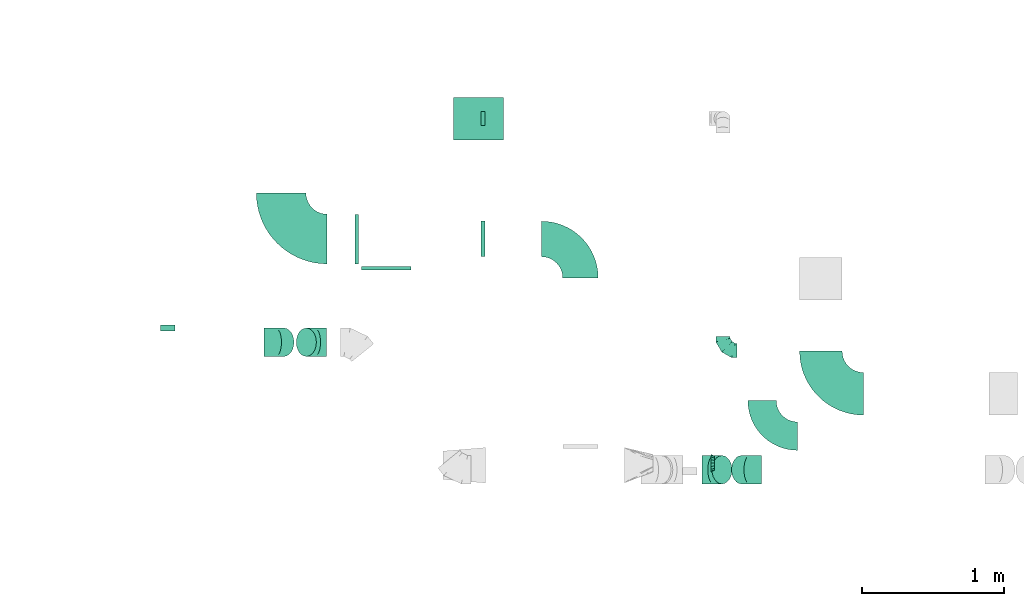
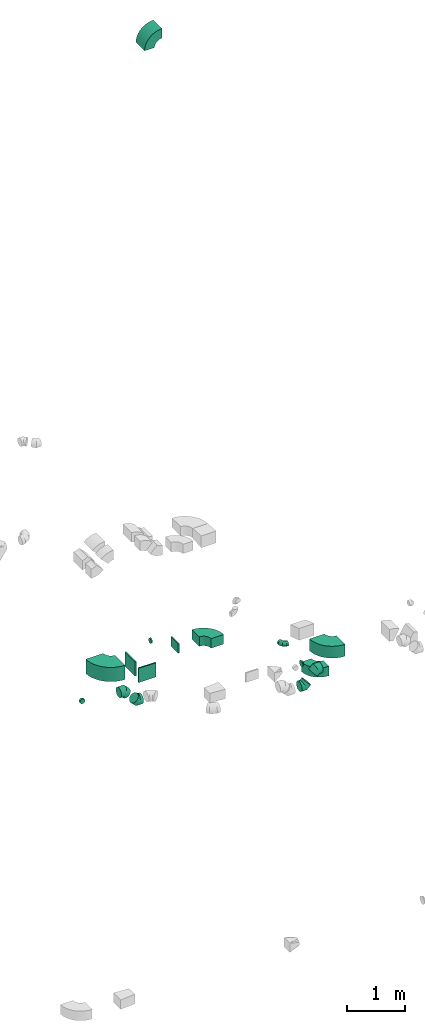
# One storey, part 29 of 44: 16 flow fittings.
"""IFC2X3 building model written with IfcOpenShell, lengths in millimetres."""

from ifc_helpers import new_model, entity, si_unit, converted_unit, derived_unit, direction, frame, frame_2d, origin, origin_2d_with_axis, place, context, subcontext, project, spatial, polyline, circle_curve, parameter, trimmed, segment, composite_curve, rectangle, outline, extrude, faceted_brep, source, transform, mapped, material, type_object, type_shapes, element, save


model = new_model("IFC2X3")

# Units and contexts
model_context = context("Model", 3, precision=0.01, world=origin(), true_north=direction((6.12303176911189e-17, 1.0)))
body_context = subcontext(model_context, "Body", "Model", "MODEL_VIEW")
ifc_project = project(units=[si_unit("LENGTHUNIT", "METRE", prefix="MILLI"), si_unit("AREAUNIT", "SQUARE_METRE"), si_unit("VOLUMEUNIT", "CUBIC_METRE"), converted_unit("PLANEANGLEUNIT", "DEGREE", entity("IfcRatioMeasure", 0.0174532925199433), si_unit("PLANEANGLEUNIT", "RADIAN"), dimensions=[0, 0, 0, 0, 0, 0, 0]), si_unit("MASSUNIT", "GRAM", prefix="KILO"), derived_unit("MASSDENSITYUNIT", [(si_unit("MASSUNIT", "GRAM", prefix="KILO"), 1), (si_unit("LENGTHUNIT", "METRE"), -3)]), derived_unit("MOMENTOFINERTIAUNIT", [(si_unit("LENGTHUNIT", "METRE"), 4)]), si_unit("TIMEUNIT", "SECOND"), si_unit("FREQUENCYUNIT", "HERTZ"), si_unit("THERMODYNAMICTEMPERATUREUNIT", "DEGREE_CELSIUS"), derived_unit("THERMALTRANSMITTANCEUNIT", [(si_unit("MASSUNIT", "GRAM", prefix="KILO"), 1), (si_unit("THERMODYNAMICTEMPERATUREUNIT", "KELVIN"), -1), (si_unit("TIMEUNIT", "SECOND"), -3)]), derived_unit("VOLUMETRICFLOWRATEUNIT", [(si_unit("LENGTHUNIT", "METRE"), 3), (si_unit("TIMEUNIT", "SECOND"), -1)]), derived_unit("MASSFLOWRATEUNIT", [(si_unit("MASSUNIT", "GRAM", prefix="KILO"), 1), (si_unit("TIMEUNIT", "SECOND"), -1)]), derived_unit("ROTATIONALFREQUENCYUNIT", [(si_unit("TIMEUNIT", "SECOND"), -1)]), si_unit("ELECTRICCURRENTUNIT", "AMPERE"), si_unit("ELECTRICVOLTAGEUNIT", "VOLT"), si_unit("POWERUNIT", "WATT"), si_unit("FORCEUNIT", "NEWTON", prefix="KILO"), si_unit("ILLUMINANCEUNIT", "LUX"), si_unit("LUMINOUSFLUXUNIT", "LUMEN"), si_unit("LUMINOUSINTENSITYUNIT", "CANDELA"), derived_unit("USERDEFINED", [(si_unit("MASSUNIT", "GRAM", prefix="KILO"), -1), (si_unit("LENGTHUNIT", "METRE"), -2), (si_unit("TIMEUNIT", "SECOND"), 3), (si_unit("LUMINOUSFLUXUNIT", "LUMEN"), 1)]), derived_unit("LINEARVELOCITYUNIT", [(si_unit("LENGTHUNIT", "METRE"), 1), (si_unit("TIMEUNIT", "SECOND"), -1)]), si_unit("PRESSUREUNIT", "PASCAL"), derived_unit("USERDEFINED", [(si_unit("LENGTHUNIT", "METRE"), -2), (si_unit("MASSUNIT", "GRAM", prefix="KILO"), 1), (si_unit("TIMEUNIT", "SECOND"), -2)]), derived_unit("LINEARFORCEUNIT", [(si_unit("MASSUNIT", "GRAM", prefix="KILO"), 1), (si_unit("LENGTHUNIT", "METRE"), 1), (si_unit("TIMEUNIT", "SECOND"), -2), (si_unit("LENGTHUNIT", "METRE"), -1)]), derived_unit("PLANARFORCEUNIT", [(si_unit("MASSUNIT", "GRAM", prefix="KILO"), 1), (si_unit("LENGTHUNIT", "METRE"), 1), (si_unit("TIMEUNIT", "SECOND"), -2), (si_unit("LENGTHUNIT", "METRE"), -2)])], contexts=[model_context])

# Site, building, storey
site_placement = place(None, origin())
site = spatial("IfcSite", under=ifc_project, at=site_placement, CompositionType="ELEMENT")
building_placement = place(site_placement, origin())
building = spatial("IfcBuilding", under=site, at=building_placement, CompositionType="ELEMENT")
storey_placement = place(building_placement, frame((0.0, 0.0, 15900.0)))
storey = spatial("IfcBuildingStorey", under=building, at=storey_placement, CompositionType="ELEMENT", Elevation=15900.0)

# Flow fittings
ifc_material = material()
duct_fitting_type_1 = type_object("IfcDuctFittingType", PredefinedType="NOTDEFINED", material=ifc_material)
shared_shape_1 = source(origin(), body_context, "Body", "SweptSolid", [
    extrude(rectangle(XDim=26.0960000000005, YDim=300.0, at=origin_2d_with_axis()), frame((6.95, 0.0, -175.0)), (0.0, 0.0, 1.0), 350.0),
])
type_shapes(duct_fitting_type_1, [shared_shape_1])
for number, where, z_axis, x_axis in (
    (1, (58980.48, 10765.63, 3158.88), (-1.0, 0.0, 0.0), (0.0, -1.0, 0.0)),
    (2, (58780.38, 10964.64, 3284.58), (0.0, 1.0, 0.0), (-1.0, 0.0, 0.0)),
):
    element("IfcFlowFitting", number, at=place(storey_placement, frame(where, z_axis=z_axis, x_axis=x_axis)), inside=storey, type_object=duct_fitting_type_1, material=ifc_material, context=body_context, shape_type="MappedRepresentation", body=[
        mapped(shared_shape_1, transform((0.0, 0.0, 0.0), scale=1.0)),
    ])
duct_fitting_type_2 = type_object("IfcDuctFittingType", PredefinedType="NOTDEFINED", material=ifc_material)
shared_shape_2 = source(origin(), body_context, "Body", "SweptSolid", [
    extrude(rectangle(XDim=26.0960000000003, YDim=200.0, at=origin_2d_with_axis()), frame((6.95, 0.0, -125.0)), (0.0, 0.0, 1.0), 250.0),
])
type_shapes(duct_fitting_type_2, [shared_shape_2])
flow_fitting_1_placement = place(storey_placement, frame((59655.56, 10965.63, 3375.0), z_axis=(0.0, -1.0, 0.0), x_axis=(1.0, 0.0, 0.0)))
element("IfcFlowFitting", 3, at=flow_fitting_1_placement, inside=storey, type_object=duct_fitting_type_2, material=ifc_material, context=body_context, shape_type="MappedRepresentation", body=[
    mapped(shared_shape_2, transform((0.0, 0.0, 0.0), scale=1.0)),
])
duct_fitting_type_3 = type_object("IfcDuctFittingType", PredefinedType="NOTDEFINED", material=ifc_material)
shared_shape_3 = source(origin(), body_context, "Body", "Brep", [
    faceted_brep([(-100.0, 0.0, -50.0), (-100.0, -12.94, -48.3), (-100.0, -25.0, -43.3), (-100.0, -35.36, -35.36), (-100.0, -43.3, -25.0), (-100.0, -48.3, -12.94), (-100.0, -50.0, 0.0), (-100.0, -48.3, 12.94), (-100.0, -43.3, 25.0), (-100.0, -35.36, 35.36), (-100.0, -25.0, 43.3), (-100.0, -12.94, 48.3), (-100.0, 0.0, 50.0), (-100.0, 12.94, 48.3), (-100.0, 25.0, 43.3), (-100.0, 35.36, 35.36), (-100.0, 43.3, 25.0), (-100.0, 48.3, 12.94), (-100.0, 50.0, 0.0), (-100.0, 48.3, -12.94), (-100.0, 43.3, -25.0), (-100.0, 35.36, -35.36), (-100.0, 25.0, -43.3), (-100.0, 12.94, -48.3), (-76.67, 12.94, 48.3), (-79.9, 25.0, 43.3), (-73.21, 0.0, 50.0), (-82.68, 35.36, 35.36), (-86.15, 48.3, 12.94), (-86.6, 50.0, 0.0), (-84.81, 43.3, 25.0), (-84.81, 43.3, -25.0), (-82.68, 35.36, -35.36), (-86.15, 48.3, -12.94), (-76.67, 12.94, -48.3), (-73.21, 0.0, -50.0), (-79.9, 25.0, -43.3), (-69.74, -12.94, -48.3), (-66.51, -25.0, -43.3), (-63.73, -35.36, -35.36), (-61.6, -43.3, -25.0), (-60.26, -48.3, -12.94), (-59.81, -50.0, 0.0), (-60.26, -48.3, 12.94), (-61.6, -43.3, 25.0), (-63.73, -35.36, 35.36), (-66.51, -25.0, 43.3), (-69.74, -12.94, 48.3), (-36.27, 36.27, 48.3), (-45.1, 45.1, 43.3), (-26.79, 26.79, 50.0), (-52.68, 52.68, 35.36), (-58.49, 58.49, 25.0), (-62.15, 62.15, 12.94), (-63.4, 63.4, 0.0), (-62.15, 62.15, -12.94), (-58.49, 58.49, -25.0), (-52.68, 52.68, -35.36), (-36.27, 36.27, -48.3), (-26.79, 26.79, -50.0), (-45.1, 45.1, -43.3), (-17.32, 17.32, -48.3), (-8.49, 8.49, -43.3), (-0.91, 0.91, -35.36), (4.9, -4.9, -25.0), (8.56, -8.56, -12.94), (9.81, -9.81, 0.0), (8.56, -8.56, 12.94), (4.9, -4.9, 25.0), (-0.91, 0.91, 35.36), (-8.49, 8.49, 43.3), (-17.32, 17.32, 48.3), (-12.94, 76.67, 48.3), (-25.0, 79.9, 43.3), (0.0, 73.21, 50.0), (-35.36, 82.68, 35.36), (-43.3, 84.81, 25.0), (-48.3, 86.15, 12.94), (-50.0, 86.6, 0.0), (-48.3, 86.15, -12.94), (-43.3, 84.81, -25.0), (-35.36, 82.68, -35.36), (-12.94, 76.67, -48.3), (0.0, 73.21, -50.0), (-25.0, 79.9, -43.3), (12.94, 69.74, -48.3), (25.0, 66.51, -43.3), (35.36, 63.73, -35.36), (43.3, 61.6, -25.0), (48.3, 60.26, -12.94), (50.0, 59.81, 0.0), (48.3, 60.26, 12.94), (43.3, 61.6, 25.0), (35.36, 63.73, 35.36), (25.0, 66.51, 43.3), (12.94, 69.74, 48.3), (-12.94, 100.0, -48.3), (-25.0, 100.0, -43.3), (-35.36, 100.0, -35.36), (-43.3, 100.0, -25.0), (-48.3, 100.0, -12.94), (-50.0, 100.0, 0.0), (-48.3, 100.0, 12.94), (-43.3, 100.0, 25.0), (-35.36, 100.0, 35.36), (-25.0, 100.0, 43.3), (-12.94, 100.0, 48.3), (0.0, 100.0, 50.0), (12.94, 100.0, 48.3), (25.0, 100.0, 43.3), (35.36, 100.0, 35.36), (43.3, 100.0, 25.0), (48.3, 100.0, 12.94), (50.0, 100.0, 0.0), (48.3, 100.0, -12.94), (43.3, 100.0, -25.0), (35.36, 100.0, -35.36), (25.0, 100.0, -43.3), (12.94, 100.0, -48.3), (0.0, 100.0, -50.0)], [[[0, 1, 2, 3, 4, 5, 6, 7, 8, 9, 10, 11, 12, 13, 14, 15, 16, 17, 18, 19, 20, 21, 22, 23]], [[24, 25, 14, 13]], [[26, 24, 13, 12]], [[14, 25, 27, 15]], [[28, 29, 18, 17]], [[30, 28, 17, 16]], [[15, 27, 30, 16]], [[20, 31, 32, 21]], [[33, 31, 20, 19]], [[18, 29, 33, 19]], [[34, 35, 0, 23]], [[36, 34, 23, 22]], [[32, 36, 22, 21]], [[2, 1, 37, 38]], [[3, 2, 38, 39]], [[0, 35, 37, 1]], [[5, 4, 40, 41]], [[6, 5, 41, 42]], [[3, 39, 40, 4]], [[6, 42, 43, 7]], [[7, 43, 44, 8]], [[8, 44, 45, 9]], [[10, 46, 47, 11]], [[11, 47, 26, 12]], [[10, 9, 45, 46]], [[48, 49, 25, 24]], [[50, 48, 24, 26]], [[27, 25, 49, 51]], [[52, 53, 28, 30]], [[51, 52, 30, 27]], [[29, 28, 53, 54]], [[55, 56, 31, 33]], [[54, 55, 33, 29]], [[57, 32, 31, 56]], [[58, 59, 35, 34]], [[60, 58, 34, 36]], [[57, 60, 36, 32]], [[37, 35, 59, 61]], [[38, 37, 61, 62]], [[39, 38, 62, 63]], [[41, 40, 64, 65]], [[42, 41, 65, 66]], [[63, 64, 40, 39]], [[43, 42, 66, 67]], [[44, 43, 67, 68]], [[68, 69, 45, 44]], [[46, 45, 69, 70]], [[47, 46, 70, 71]], [[26, 47, 71, 50]], [[72, 73, 49, 48]], [[74, 72, 48, 50]], [[51, 49, 73, 75]], [[76, 77, 53, 52]], [[75, 76, 52, 51]], [[54, 53, 77, 78]], [[79, 80, 56, 55]], [[78, 79, 55, 54]], [[81, 57, 56, 80]], [[82, 83, 59, 58]], [[84, 82, 58, 60]], [[81, 84, 60, 57]], [[61, 59, 83, 85]], [[62, 61, 85, 86]], [[63, 62, 86, 87]], [[65, 64, 88, 89]], [[66, 65, 89, 90]], [[87, 88, 64, 63]], [[67, 66, 90, 91]], [[68, 67, 91, 92]], [[92, 93, 69, 68]], [[70, 69, 93, 94]], [[71, 70, 94, 95]], [[50, 71, 95, 74]], [[96, 97, 98, 99, 100, 101, 102, 103, 104, 105, 106, 107, 108, 109, 110, 111, 112, 113, 114, 115, 116, 117, 118, 119]], [[72, 74, 107, 106]], [[73, 72, 106, 105]], [[75, 73, 105, 104]], [[77, 76, 103, 102]], [[78, 77, 102, 101]], [[75, 104, 103, 76]], [[78, 101, 100, 79]], [[79, 100, 99, 80]], [[80, 99, 98, 81]], [[96, 119, 83, 82]], [[97, 96, 82, 84]], [[84, 81, 98, 97]], [[83, 119, 118, 85]], [[85, 118, 117, 86]], [[86, 117, 116, 87]], [[88, 115, 114, 89]], [[89, 114, 113, 90]], [[87, 116, 115, 88]], [[91, 90, 113, 112]], [[92, 91, 112, 111]], [[93, 92, 111, 110]], [[95, 94, 109, 108]], [[74, 95, 108, 107]], [[110, 109, 94, 93]]]),
])
type_shapes(duct_fitting_type_3, [shared_shape_3])
flow_fitting_2_placement = place(storey_placement, frame((61355.06, 10179.05, 3260.0), z_axis=(0.0, 0.0, 1.0), x_axis=(0.0, -1.0, 0.0)))
element("IfcFlowFitting", 4, at=flow_fitting_2_placement, inside=storey, type_object=duct_fitting_type_3, material=ifc_material, context=body_context, shape_type="MappedRepresentation", body=[
    mapped(shared_shape_3, transform((0.0, 0.0, 0.0), scale=1.0)),
])
duct_fitting_type_4 = type_object("IfcDuctFittingType", PredefinedType="NOTDEFINED", material=ifc_material)
shared_shape_4 = source(origin(), body_context, "Body", "Brep", [
    faceted_brep([(-82.84, 0.0, -100.0), (-82.84, -25.88, -96.59), (-82.84, -50.0, -86.6), (-82.84, -70.71, -70.71), (-82.84, -86.6, -50.0), (-82.84, -96.59, -25.88), (-82.84, -100.0, 0.0), (-82.84, -96.59, 25.88), (-82.84, -86.6, 50.0), (-82.84, -70.71, 70.71), (-82.84, -50.0, 86.6), (-82.84, -25.88, 96.59), (-82.84, 0.0, 100.0), (-82.84, 25.88, 96.59), (-82.84, 50.0, 86.6), (-82.84, 70.71, 70.71), (-82.84, 86.6, 50.0), (-82.84, 96.59, 25.88), (-82.84, 100.0, 0.0), (-82.84, 96.59, -25.88), (-82.84, 86.6, -50.0), (-82.84, 70.71, -70.71), (-82.84, 50.0, -86.6), (-82.84, 25.88, -96.59), (-10.72, 25.88, 96.59), (-20.71, 50.0, 86.6), (0.0, 0.0, 100.0), (-29.29, 70.71, 70.71), (-35.87, 86.6, 50.0), (-40.01, 96.59, 25.88), (-41.42, 100.0, 0.0), (-40.01, 96.59, -25.88), (-35.87, 86.6, -50.0), (-29.29, 70.71, -70.71), (-10.72, 25.88, -96.59), (0.0, 0.0, -100.0), (-20.71, 50.0, -86.6), (10.72, -25.88, -96.59), (20.71, -50.0, -86.6), (29.29, -70.71, -70.71), (35.87, -86.6, -50.0), (40.01, -96.59, -25.88), (41.42, -100.0, 0.0), (40.01, -96.59, 25.88), (35.87, -86.6, 50.0), (29.29, -70.71, 70.71), (20.71, -50.0, 86.6), (10.72, -25.88, 96.59), (58.58, 58.58, 100.0), (40.28, 76.88, 96.59), (23.22, 93.93, 86.6), (8.58, 108.58, 70.71), (-2.66, 119.82, 50.0), (-9.72, 126.88, 25.88), (-12.13, 129.29, 0.0), (-9.72, 126.88, -25.88), (-2.66, 119.82, -50.0), (8.58, 108.58, -70.71), (23.22, 93.93, -86.6), (40.28, 76.88, -96.59), (58.58, 58.58, -100.0), (76.88, 40.28, -96.59), (93.93, 23.22, -86.6), (108.58, 8.58, -70.71), (119.82, -2.66, -50.0), (126.88, -9.72, -25.88), (129.29, -12.13, 0.0), (126.88, -9.72, 25.88), (119.82, -2.66, 50.0), (108.58, 8.58, 70.71), (93.93, 23.22, 86.6), (76.88, 40.28, 96.59)], [[[0, 1, 2, 3, 4, 5, 6, 7, 8, 9, 10, 11, 12, 13, 14, 15, 16, 17, 18, 19, 20, 21, 22, 23]], [[24, 25, 14, 13]], [[26, 24, 13, 12]], [[14, 25, 27, 15]], [[28, 29, 17, 16]], [[28, 16, 15, 27]], [[30, 18, 17, 29]], [[31, 32, 20, 19]], [[30, 31, 19, 18]], [[32, 33, 21, 20]], [[34, 35, 0, 23]], [[36, 34, 23, 22]], [[33, 36, 22, 21]], [[1, 0, 35, 37]], [[2, 1, 37, 38]], [[38, 39, 3, 2]], [[5, 4, 40, 41]], [[6, 5, 41, 42]], [[39, 40, 4, 3]], [[6, 42, 43, 7]], [[7, 43, 44, 8]], [[8, 44, 45, 9]], [[9, 45, 46, 10]], [[10, 46, 47, 11]], [[26, 12, 11, 47]], [[24, 26, 48, 49]], [[25, 24, 49, 50]], [[27, 25, 50, 51]], [[29, 28, 52, 53]], [[30, 29, 53, 54]], [[51, 52, 28, 27]], [[30, 54, 55, 31]], [[31, 55, 56, 32]], [[57, 33, 32, 56]], [[36, 58, 59, 34]], [[34, 59, 60, 35]], [[58, 36, 33, 57]], [[35, 60, 61, 37]], [[37, 61, 62, 38]], [[63, 39, 38, 62]], [[40, 64, 65, 41]], [[41, 65, 66, 42]], [[64, 40, 39, 63]], [[43, 42, 66, 67]], [[44, 43, 67, 68]], [[68, 69, 45, 44]], [[47, 46, 70, 71]], [[26, 47, 71, 48]], [[69, 70, 46, 45]], [[59, 58, 57, 56, 55, 54, 53, 52, 51, 50, 49, 48, 71, 70, 69, 68, 67, 66, 65, 64, 63, 62, 61, 60]]]),
])
type_shapes(duct_fitting_type_4, [shared_shape_4])
for number, where, z_axis, x_axis in (
    (5, (58475.71, 10237.4, 3074.82), (0.0, 1.0, 0.0), (-1.0, 0.0, 0.0)),
    (6, (58200.53, 10237.4, 3350.0), (0.0, -1.0, 0.0), (-0.70710678118653, 0.0, 0.707106781186565)),
    (7, (61288.67, 9338.57, 2945.0), (0.0, -1.0, 0.0), (1.0, 0.0, 0.0)),
    (8, (61543.67, 9338.57, 3200.0), (0.0, 1.0, 0.0), (0.707106781186468, 0.0, 0.707106781186627)),
):
    element("IfcFlowFitting", number, at=place(storey_placement, frame(where, z_axis=z_axis, x_axis=x_axis)), inside=storey, type_object=duct_fitting_type_4, material=ifc_material, context=body_context, shape_type="MappedRepresentation", body=[
        mapped(shared_shape_4, transform((0.0, 0.0, 0.0), scale=1.0)),
    ])
duct_fitting_type_5 = type_object("IfcDuctFittingType", PredefinedType="NOTDEFINED", material=ifc_material)
shared_shape_5 = source(origin(), body_context, "Body", "Brep", [
    faceted_brep([(20.0, 0.0, -50.0), (20.0, 12.94, -48.3), (20.0, 25.0, -43.3), (20.0, 35.36, -35.36), (20.0, 43.3, -25.0), (20.0, 48.3, -12.94), (20.0, 50.0, 0.0), (20.0, 48.3, 12.94), (20.0, 43.3, 25.0), (20.0, 35.36, 35.36), (20.0, 25.0, 43.3), (20.0, 12.94, 48.3), (20.0, 0.0, 50.0), (20.0, -12.94, 48.3), (20.0, -25.0, 43.3), (20.0, -35.36, 35.36), (20.0, -43.3, 25.0), (20.0, -48.3, 12.94), (20.0, -50.0, 0.0), (20.0, -48.3, -12.94), (20.0, -43.3, -25.0), (20.0, -35.36, -35.36), (20.0, -25.0, -43.3), (20.0, -12.94, -48.3), (0.0, 0.0, 50.0), (-19.49, 0.0, 50.0), (-19.49, -12.94, 48.3), (0.0, -12.94, 48.3), (-19.49, -25.0, 43.3), (0.0, -25.0, 43.3), (0.0, -35.36, 35.36), (-19.49, -35.36, 35.36), (0.0, -43.3, 25.0), (-19.49, -43.3, 25.0), (-19.49, -48.3, 12.94), (0.0, -48.3, 12.94), (-19.49, -50.0, 0.0), (0.0, -50.0, 0.0), (-19.49, -48.3, -12.94), (0.0, -48.3, -12.94), (-19.49, -43.3, -25.0), (0.0, -43.3, -25.0), (0.0, -35.36, -35.36), (-19.49, -35.36, -35.36), (0.0, -25.0, -43.3), (-19.49, -25.0, -43.3), (-19.49, -12.94, -48.3), (0.0, -12.94, -48.3), (-19.49, 0.0, -50.0), (0.0, 0.0, -50.0), (-19.49, 12.94, -48.3), (0.0, 12.94, -48.3), (-19.49, 25.0, -43.3), (0.0, 25.0, -43.3), (0.0, 35.36, -35.36), (-19.49, 35.36, -35.36), (0.0, 43.3, -25.0), (-19.49, 43.3, -25.0), (-19.49, 48.3, -12.94), (0.0, 48.3, -12.94), (-19.49, 50.0, 0.0), (0.0, 50.0, 0.0), (-19.49, 48.3, 12.94), (0.0, 48.3, 12.94), (-19.49, 43.3, 25.0), (0.0, 43.3, 25.0), (0.0, 35.36, 35.36), (-19.49, 35.36, 35.36), (0.0, 25.0, 43.3), (-19.49, 25.0, 43.3), (-19.49, 12.94, 48.3), (0.0, 12.94, 48.3)], [[[0, 1, 2, 3, 4, 5, 6, 7, 8, 9, 10, 11, 12, 13, 14, 15, 16, 17, 18, 19, 20, 21, 22, 23]], [[13, 12, 24, 25, 26, 27]], [[14, 13, 27, 26, 28, 29]], [[30, 15, 14, 29, 28, 31]], [[17, 16, 32, 33, 34, 35]], [[18, 17, 35, 34, 36, 37]], [[32, 16, 15, 30, 31, 33]], [[19, 18, 37, 36, 38, 39]], [[20, 19, 39, 38, 40, 41]], [[42, 21, 20, 41, 40, 43]], [[23, 22, 44, 45, 46, 47]], [[0, 23, 47, 46, 48, 49]], [[44, 22, 21, 42, 43, 45]], [[1, 0, 49, 48, 50, 51]], [[2, 1, 51, 50, 52, 53]], [[54, 3, 2, 53, 52, 55]], [[5, 4, 56, 57, 58, 59]], [[6, 5, 59, 58, 60, 61]], [[56, 4, 3, 54, 55, 57]], [[7, 6, 61, 60, 62, 63]], [[8, 7, 63, 62, 64, 65]], [[66, 9, 8, 65, 64, 67]], [[11, 10, 68, 69, 70, 71]], [[12, 11, 71, 70, 25, 24]], [[68, 10, 9, 66, 67, 69]], [[46, 45, 43, 40, 38, 36, 34, 33, 31, 28, 26, 25, 70, 69, 67, 64, 62, 60, 58, 57, 55, 52, 50, 48]]]),
])
type_shapes(duct_fitting_type_5, [shared_shape_5])
flow_fitting_3_placement = place(storey_placement, frame((57439.44, 10337.4, 3350.0), z_axis=(0.0, 7.45053264831263e-07, -1.0), x_axis=(0.0, 1.0, 7.45053263408281e-07)))
element("IfcFlowFitting", 9, at=flow_fitting_3_placement, inside=storey, type_object=duct_fitting_type_5, material=ifc_material, context=body_context, shape_type="MappedRepresentation", body=[
    mapped(shared_shape_5, transform((0.0, 0.0, 0.0), scale=1.0)),
])
duct_fitting_type_6 = type_object("IfcDuctFittingType", PredefinedType="NOTDEFINED", material=ifc_material)
shared_shape_6 = source(origin(), body_context, "Body", "Brep", [
    faceted_brep([(25.0, 0.0, -62.5), (25.0, 12.45, -60.02), (25.0, 23.92, -57.74), (25.0, 34.06, -50.97), (25.0, 44.19, -44.19), (25.0, 50.97, -34.06), (25.0, 57.74, -23.92), (25.0, 60.02, -12.45), (25.0, 62.5, 0.0), (25.0, 60.02, 12.45), (25.0, 57.74, 23.92), (25.0, 50.97, 34.06), (25.0, 44.19, 44.19), (25.0, 34.06, 50.97), (25.0, 23.92, 57.74), (25.0, 12.45, 60.02), (25.0, 0.0, 62.5), (25.0, -12.45, 60.02), (25.0, -23.92, 57.74), (25.0, -34.06, 50.97), (25.0, -44.19, 44.19), (25.0, -50.97, 34.06), (25.0, -57.74, 23.92), (25.0, -60.02, 12.45), (25.0, -62.5, 0.0), (25.0, -60.02, -12.45), (25.0, -57.74, -23.92), (25.0, -50.97, -34.06), (25.0, -44.19, -44.19), (25.0, -34.06, -50.97), (25.0, -23.92, -57.74), (25.0, -12.45, -60.02), (0.0, -19.13, -46.19), (0.0, -27.24, -40.77), (0.0, -35.36, -35.36), (0.0, -40.77, -27.24), (0.0, -46.19, -19.13), (0.0, -48.1, -9.57), (0.0, -50.0, 0.0), (0.0, -48.1, 9.57), (0.0, -46.19, 19.13), (0.0, -40.77, 27.24), (0.0, -35.36, 35.36), (0.0, -27.24, 40.77), (0.0, -19.13, 46.19), (0.0, -9.57, 48.1), (0.0, 0.0, 50.0), (0.0, 9.57, 48.1), (0.0, 19.13, 46.19), (0.0, 27.24, 40.77), (0.0, 35.36, 35.36), (0.0, 40.77, 27.24), (0.0, 46.19, 19.13), (0.0, 48.1, 9.57), (0.0, 50.0, 0.0), (0.0, 48.1, -9.57), (0.0, 46.19, -19.13), (0.0, 40.77, -27.24), (0.0, 35.36, -35.36), (0.0, 27.24, -40.77), (0.0, 19.13, -46.19), (0.0, 9.57, -48.1), (0.0, 0.0, -50.0), (0.0, -9.57, -48.1)], [[[0, 1, 2, 3, 4, 5, 6, 7, 8, 9, 10, 11, 12, 13, 14, 15, 16, 17, 18, 19, 20, 21, 22, 23, 24, 25, 26, 27, 28, 29, 30, 31]], [[32, 33, 34, 35, 36, 37, 38, 39, 40, 41, 42, 43, 44, 45, 46, 47, 48, 49, 50, 51, 52, 53, 54, 55, 56, 57, 58, 59, 60, 61, 62, 63]], [[52, 10, 9, 8, 54, 53]], [[51, 50, 12, 11, 10, 52]], [[47, 46, 16, 15, 14, 48]], [[49, 48, 14, 13, 12, 50]], [[44, 18, 17, 16, 46, 45]], [[43, 42, 20, 19, 18, 44]], [[39, 38, 24, 23, 22, 40]], [[41, 40, 22, 21, 20, 42]], [[36, 26, 25, 24, 38, 37]], [[35, 34, 28, 27, 26, 36]], [[63, 62, 0, 31, 30, 32]], [[33, 32, 30, 29, 28, 34]], [[60, 2, 1, 0, 62, 61]], [[59, 58, 4, 3, 2, 60]], [[55, 54, 8, 7, 6, 56]], [[57, 56, 6, 5, 4, 58]]]),
])
type_shapes(duct_fitting_type_6, [shared_shape_6])
flow_fitting_4_placement = place(storey_placement, frame((61294.84, 9385.12, 3375.0), z_axis=(0.0, 0.0, 1.0), x_axis=(-1.0, 0.0, 0.0)))
element("IfcFlowFitting", 10, at=flow_fitting_4_placement, inside=storey, type_object=duct_fitting_type_6, material=ifc_material, context=body_context, shape_type="MappedRepresentation", body=[
    mapped(shared_shape_6, transform((0.0, 0.0, 0.0), scale=1.0)),
])
duct_fitting_type_7 = type_object("IfcDuctFittingType", PredefinedType="NOTDEFINED", material=ifc_material)
shared_shape_7 = source(origin(), body_context, "Body", "Brep", [
    faceted_brep([(20.0, 12.94, -48.3), (20.0, 25.0, -43.3), (20.0, 35.36, -35.36), (20.0, 43.3, -25.0), (20.0, 48.3, -12.94), (20.0, 50.0, 0.0), (20.0, 48.3, 12.94), (20.0, 43.3, 25.0), (20.0, 35.36, 35.36), (20.0, 25.0, 43.3), (20.0, 12.94, 48.3), (20.0, 0.0, 50.0), (20.0, -12.94, 48.3), (20.0, -25.0, 43.3), (20.0, -35.36, 35.36), (20.0, -43.3, 25.0), (20.0, -48.3, 12.94), (20.0, -50.0, 0.0), (20.0, -48.3, -12.94), (20.0, -43.3, -25.0), (20.0, -35.36, -35.36), (20.0, -25.0, -43.3), (20.0, -12.94, -48.3), (20.0, 0.0, -50.0), (0.0, 0.0, 50.0), (0.0, 12.94, 48.3), (-6.1, 12.94, 48.3), (-6.1, 0.0, 50.0), (0.0, 25.0, 43.3), (-6.1, 25.0, 43.3), (0.0, 35.36, 35.36), (-6.1, 35.36, 35.36), (0.0, 43.3, 25.0), (0.0, 48.3, 12.94), (-6.1, 48.3, 12.94), (-6.1, 43.3, 25.0), (0.0, 50.0, 0.0), (-6.1, 50.0, 0.0), (0.0, 48.3, -12.94), (-6.1, 48.3, -12.94), (0.0, 43.3, -25.0), (-6.1, 43.3, -25.0), (0.0, 35.36, -35.36), (-6.1, 35.36, -35.36), (0.0, 25.0, -43.3), (0.0, 12.94, -48.3), (-6.1, 12.94, -48.3), (-6.1, 25.0, -43.3), (0.0, 0.0, -50.0), (-6.1, 0.0, -50.0), (0.0, -12.94, -48.3), (-6.1, -12.94, -48.3), (0.0, -25.0, -43.3), (-6.1, -25.0, -43.3), (0.0, -35.36, -35.36), (-6.1, -35.36, -35.36), (0.0, -43.3, -25.0), (0.0, -48.3, -12.94), (-6.1, -48.3, -12.94), (-6.1, -43.3, -25.0), (0.0, -50.0, 0.0), (-6.1, -50.0, 0.0), (0.0, -48.3, 12.94), (-6.1, -48.3, 12.94), (0.0, -43.3, 25.0), (-6.1, -43.3, 25.0), (0.0, -35.36, 35.36), (-6.1, -35.36, 35.36), (0.0, -25.0, 43.3), (0.0, -12.94, 48.3), (-6.1, -12.94, 48.3), (-6.1, -25.0, 43.3)], [[[0, 1, 2, 3, 4, 5, 6, 7, 8, 9, 10, 11, 12, 13, 14, 15, 16, 17, 18, 19, 20, 21, 22, 23]], [[24, 11, 10, 25, 26, 27]], [[25, 10, 9, 28, 29, 26]], [[28, 9, 8, 30, 31, 29]], [[32, 7, 6, 33, 34, 35]], [[33, 6, 5, 36, 37, 34]], [[30, 8, 7, 32, 35, 31]], [[36, 5, 4, 38, 39, 37]], [[38, 4, 3, 40, 41, 39]], [[40, 3, 2, 42, 43, 41]], [[44, 1, 0, 45, 46, 47]], [[45, 0, 23, 48, 49, 46]], [[42, 2, 1, 44, 47, 43]], [[48, 23, 22, 50, 51, 49]], [[50, 22, 21, 52, 53, 51]], [[52, 21, 20, 54, 55, 53]], [[56, 19, 18, 57, 58, 59]], [[57, 18, 17, 60, 61, 58]], [[54, 20, 19, 56, 59, 55]], [[60, 17, 16, 62, 63, 61]], [[62, 16, 15, 64, 65, 63]], [[64, 15, 14, 66, 67, 65]], [[68, 13, 12, 69, 70, 71]], [[69, 12, 11, 24, 27, 70]], [[66, 14, 13, 68, 71, 67]], [[49, 51, 53, 55, 59, 58, 61, 63, 65, 67, 71, 70, 27, 26, 29, 31, 35, 34, 37, 39, 41, 43, 47, 46]]]),
])
type_shapes(duct_fitting_type_7, [shared_shape_7])
flow_fitting_5_placement = place(storey_placement, frame((59655.69, 11814.05, 2950.0), z_axis=(0.0, -1.0, 0.0), x_axis=(1.0, 0.0, 0.0)))
element("IfcFlowFitting", 11, at=flow_fitting_5_placement, inside=storey, type_object=duct_fitting_type_7, material=ifc_material, context=body_context, shape_type="MappedRepresentation", body=[
    mapped(shared_shape_7, transform((0.0, 0.0, 0.0), scale=1.0)),
])
duct_fitting_type_8 = type_object("IfcDuctFittingType", PredefinedType="NOTDEFINED", material=ifc_material)
shared_shape_8 = source(origin(), body_context, "Body", "SweptSolid", [
    extrude(outline(composite_curve([segment(polyline([(-300.0, -150.0), (0.0, -150.0)]), True, "CONTINUOUS"), segment(trimmed(circle_curve(frame_2d((150.0, -150.0), x_axis=(0.0, 1.0)), 150.0), [parameter(0.0)], [parameter(90.0)], True, "PARAMETER"), False, "CONTINUOUS"), segment(polyline([(150.0, 0.0), (150.0, 300.0)]), True, "CONTINUOUS"), segment(trimmed(circle_curve(frame_2d((150.0, -150.0), x_axis=(0.0, 1.0)), 450.0), [parameter(0.0)], [parameter(90.0000000000001)], True, "PARAMETER"), True, "CONTINUOUS")], self_intersect=False)), frame((-150.0, 150.0, -125.0), z_axis=(0.0, 0.0, 1.0), x_axis=(-1.0, 0.0, 0.0)), (0.0, 0.0, 1.0), 250.0),
])
type_shapes(duct_fitting_type_8, [shared_shape_8])
flow_fitting_6_placement = place(storey_placement, frame((62044.65, 9874.07, 3075.0), z_axis=(0.0, 0.0, 1.0), x_axis=(0.0, -1.0, 0.0)))
element("IfcFlowFitting", 12, at=flow_fitting_6_placement, inside=storey, type_object=duct_fitting_type_8, material=ifc_material, context=body_context, shape_type="MappedRepresentation", body=[
    mapped(shared_shape_8, transform((0.0, 0.0, 0.0), scale=1.0)),
])
duct_fitting_type_9 = type_object("IfcDuctFittingType", PredefinedType="NOTDEFINED", material=ifc_material)
shared_shape_9 = source(origin(), body_context, "Body", "SweptSolid", [
    extrude(outline(composite_curve([segment(polyline([(-262.5, -137.5), (-12.5, -137.5)]), True, "CONTINUOUS"), segment(trimmed(circle_curve(frame_2d((137.5, -137.5), x_axis=(0.0, 1.0)), 150.0), [parameter(0.0)], [parameter(90.0000000000001)], True, "PARAMETER"), False, "CONTINUOUS"), segment(polyline([(137.5, 12.5), (137.5, 262.5)]), True, "CONTINUOUS"), segment(trimmed(circle_curve(frame_2d((137.5, -137.5), x_axis=(0.0, 1.0)), 400.0), [parameter(0.0)], [parameter(90.0000000000001)], True, "PARAMETER"), True, "CONTINUOUS")], self_intersect=False)), frame((-137.5, 137.5, -100.0), z_axis=(0.0, 0.0, 1.0), x_axis=(-1.0, 0.0, 0.0)), (0.0, 0.0, 1.0), 200.0),
])
type_shapes(duct_fitting_type_9, [shared_shape_9])
flow_fitting_7_placement = place(storey_placement, frame((60349.84, 10965.63, 3375.0), z_axis=(0.0, 0.0, 1.0), x_axis=(0.0, 1.0, 0.0)))
element("IfcFlowFitting", 13, at=flow_fitting_7_placement, inside=storey, type_object=duct_fitting_type_9, material=ifc_material, context=body_context, shape_type="MappedRepresentation", body=[
    mapped(shared_shape_9, transform((0.0, 0.0, 0.0), scale=1.0)),
])
duct_fitting_type_10 = type_object("IfcDuctFittingType", PredefinedType="NOTDEFINED", material=ifc_material)
shared_shape_10 = source(origin(), body_context, "Body", "SweptSolid", [
    extrude(outline(composite_curve([segment(polyline([(-337.5, -162.5), (12.5, -162.5)]), True, "CONTINUOUS"), segment(trimmed(circle_curve(frame_2d((162.5, -162.5), x_axis=(0.0, 1.0)), 150.0), [parameter(0.0)], [parameter(90.0)], True, "PARAMETER"), False, "CONTINUOUS"), segment(polyline([(162.5, -12.5), (162.5, 337.5)]), True, "CONTINUOUS"), segment(trimmed(circle_curve(frame_2d((162.5, -162.5), x_axis=(0.0, 1.0)), 500.0), [parameter(0.0)], [parameter(90.0)], True, "PARAMETER"), True, "CONTINUOUS")], self_intersect=False)), frame((-162.5, 162.5, -150.0), z_axis=(0.0, 0.0, 1.0), x_axis=(-1.0, 0.0, 0.0)), (0.0, 0.0, 1.0), 300.0),
])
type_shapes(duct_fitting_type_10, [shared_shape_10])
flow_fitting_8_placement = place(storey_placement, frame((58239.44, 10964.64, 3284.58), z_axis=(0.0, 0.0, 1.0), x_axis=(0.0, -1.0, 0.0)))
element("IfcFlowFitting", 14, at=flow_fitting_8_placement, inside=storey, type_object=duct_fitting_type_10, material=ifc_material, context=body_context, shape_type="MappedRepresentation", body=[
    mapped(shared_shape_10, transform((0.0, 0.0, 0.0), scale=1.0)),
])
duct_fitting_type_11 = type_object("IfcDuctFittingType", PredefinedType="NOTDEFINED", material=ifc_material)
shared_shape_11 = source(origin(), body_context, "Body", "SweptSolid", [
    extrude(outline(composite_curve([segment(polyline([(-225.0, -125.0), (-25.0, -125.0)]), True, "CONTINUOUS"), segment(trimmed(circle_curve(frame_2d((125.0, -125.0), x_axis=(0.0, 1.0)), 150.0), [parameter(0.0)], [parameter(90.0)], True, "PARAMETER"), False, "CONTINUOUS"), segment(polyline([(125.0, 25.0), (125.0, 225.0)]), True, "CONTINUOUS"), segment(trimmed(circle_curve(frame_2d((125.0, -125.0), x_axis=(0.0, 1.0)), 350.0), [parameter(0.0)], [parameter(90.0)], True, "PARAMETER"), True, "CONTINUOUS")], self_intersect=False)), frame((-125.0, 125.0, -100.0), z_axis=(0.0, 0.0, 1.0), x_axis=(-1.0, 0.0, 0.0)), (0.0, 0.0, 1.0), 200.0),
])
type_shapes(duct_fitting_type_11, [shared_shape_11])
flow_fitting_9_placement = place(storey_placement, frame((61630.06, 9575.53, 2950.0), z_axis=(0.0, 0.0, 1.0), x_axis=(0.0, -1.0, 0.0)))
element("IfcFlowFitting", 15, at=flow_fitting_9_placement, inside=storey, type_object=duct_fitting_type_11, material=ifc_material, context=body_context, shape_type="MappedRepresentation", body=[
    mapped(shared_shape_11, transform((0.0, 0.0, 0.0), scale=1.0)),
])
duct_fitting_type_12 = type_object("IfcDuctFittingType", PredefinedType="NOTDEFINED", material=ifc_material)
shared_shape_12 = source(origin(), body_context, "Body", "SweptSolid", [
    extrude(outline(composite_curve([segment(polyline([(-225.0, -125.0), (-25.0, -125.0)]), True, "CONTINUOUS"), segment(trimmed(circle_curve(frame_2d((125.0, -125.0), x_axis=(0.0, 1.0)), 150.0), [parameter(0.0)], [parameter(90.0)], True, "PARAMETER"), False, "CONTINUOUS"), segment(polyline([(125.0, 25.0), (125.0, 225.0)]), True, "CONTINUOUS"), segment(trimmed(circle_curve(frame_2d((125.0, -125.0), x_axis=(0.0, 1.0)), 350.0), [parameter(0.0)], [parameter(90.0)], True, "PARAMETER"), True, "CONTINUOUS")], self_intersect=False)), frame((-125.0, 125.0, -150.0), z_axis=(0.0, 0.0, 1.0), x_axis=(-1.0, 0.0, 0.0)), (0.0, 0.0, 1.0), 300.0),
])
type_shapes(duct_fitting_type_12, [shared_shape_12])
flow_fitting_10_placement = place(storey_placement, frame((59555.69, 11814.2, 15825.0), z_axis=(0.0, 1.0, 0.0), x_axis=(0.0, 0.0, 1.0)))
element("IfcFlowFitting", 16, at=flow_fitting_10_placement, inside=storey, type_object=duct_fitting_type_12, material=ifc_material, context=body_context, shape_type="MappedRepresentation", body=[
    mapped(shared_shape_12, transform((0.0, 0.0, 0.0), scale=1.0)),
])

save(model, "model.ifc")
